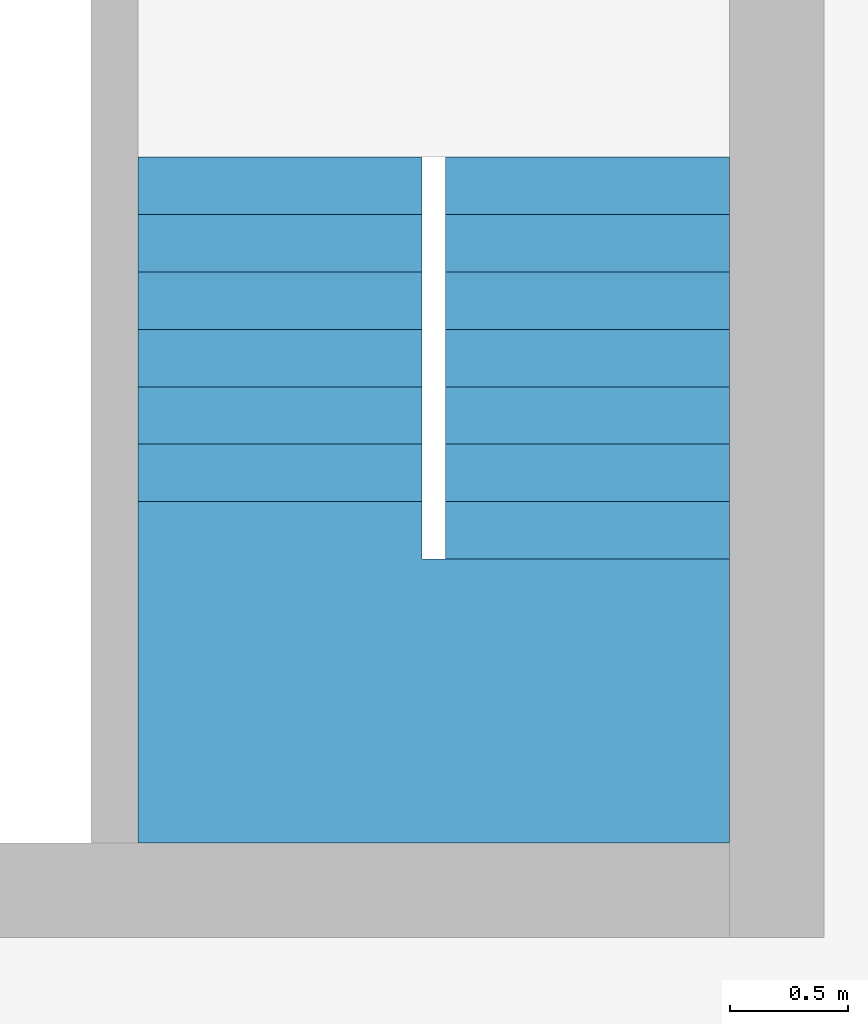
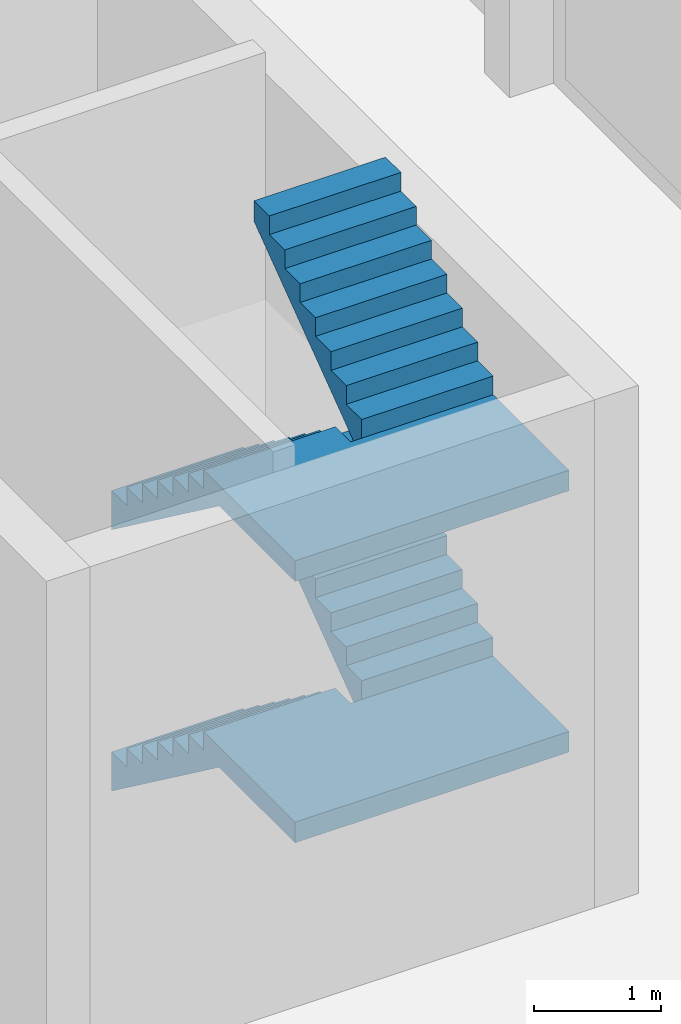
# One storey, part 2 of 5: 2 stairs.
"""IFC2X3 building model written with IfcOpenShell, lengths in metres."""

import ifcopenshell
import ifcopenshell.guid

model = None  # the IFC model being written
_history = None  # IfcOwnerHistory: only IFC2X3 demands one
_inside = {}  # id of a spatial element -> (the spatial element, [elements in it])
_under = {}  # id of a project, library or spatial element -> (it, [spatial elements below it])
_declared = {}  # id of a project -> (the project, [libraries it declares])
_typed = {}  # id of a type object -> (the type object, [elements of that type])
_made_of = {}  # id of a material, layer set ... -> (it, [elements and type objects made of it])


def new_model(schema):
    """Start an empty IFC model of exactly this schema.

    Asked for "IFC4X3", IfcOpenShell would pick the latest addendum, in which some entities
    have other attributes; the version numbers below select the first issue.
    IFC2X3 requires an IfcOwnerHistory on every rooted entity: one is made here for all.
    """
    global model, _history
    if schema == "IFC4X3":
        model = ifcopenshell.file(schema_version=(4, 3, 0, 0))
    else:
        model = ifcopenshell.file(schema=schema)
    _inside.clear()
    _under.clear()
    _declared.clear()
    _typed.clear()
    _made_of.clear()
    _history = None
    if model.schema == "IFC2X3":
        org = make("IfcOrganization", Name="unknown")
        user = make(
            "IfcPersonAndOrganization",
            ThePerson=make("IfcPerson", FamilyName="unknown"),
            TheOrganization=org,
        )
        app = make(
            "IfcApplication",
            ApplicationDeveloper=org,
            Version="unknown",
            ApplicationFullName="unknown",
            ApplicationIdentifier="unknown",
        )
        _history = make(
            "IfcOwnerHistory",
            OwningUser=user,
            OwningApplication=app,
            ChangeAction="ADDED",
            CreationDate=0,
        )
    return model


def make(cls, **values):
    """One entity of the class cls with the attributes given. An attribute that is None is left unset."""
    return model.create_entity(
        cls, **{name: value for name, value in values.items() if value is not None}
    )


def entity(cls, *values):
    """Any entity or typed value of the class cls, its attributes in the order of the schema. None: left unset."""
    e = model.create_entity(cls)
    for i, value in enumerate(values):
        if value is not None:
            e[i] = value
    return e


def rooted(cls, **values):
    """An entity with a GlobalId (a new one), such as an element, a storey or a relation."""
    return make(cls, GlobalId=ifcopenshell.guid.new(), OwnerHistory=_history, **values)


def si_unit(unit_type, name, prefix=None):
    """IfcSIUnit, for example si_unit("LENGTHUNIT", "METRE", prefix="MILLI")."""
    return make("IfcSIUnit", UnitType=unit_type, Prefix=prefix, Name=name)


def converted_unit(unit_type, name, factor, base, dimensions=None, offset=None):
    """IfcConversionBasedUnit, such as the inch: factor (a typed value) times the base unit."""
    return make(
        "IfcConversionBasedUnit"
        if offset is None
        else "IfcConversionBasedUnitWithOffset",
        ConversionOffset=offset,
        Dimensions=None
        if dimensions is None
        else entity("IfcDimensionalExponents", *dimensions),
        UnitType=unit_type,
        Name=name,
        ConversionFactor=make(
            "IfcMeasureWithUnit", ValueComponent=factor, UnitComponent=base
        ),
    )


def assignment(units):
    """IfcUnitAssignment: the units of a project."""
    return None if units is None else make("IfcUnitAssignment", Units=units)


def point(xyz):
    """IfcCartesianPoint."""
    return None if xyz is None else make("IfcCartesianPoint", Coordinates=xyz)


def direction(xyz):
    """IfcDirection."""
    return None if xyz is None else make("IfcDirection", DirectionRatios=xyz)


def frame(location, z_axis=None, x_axis=None):
    """IfcAxis2Placement3D, a coordinate frame: its origin and axes. An axis left out is left unset."""
    return make(
        "IfcAxis2Placement3D",
        Location=point(location),
        Axis=direction(z_axis),
        RefDirection=direction(x_axis),
    )


def origin():
    """The frame at (0, 0, 0) with its axes left unset."""
    return frame((0.0, 0.0, 0.0))


def place(relative_to, where):
    """IfcLocalPlacement: puts the frame where relative to a parent placement (None: the world)."""
    return make(
        "IfcLocalPlacement", PlacementRelTo=relative_to, RelativePlacement=where
    )


def context(
    kind, dimensions, precision=None, world=None, true_north=None, identifier=None
):
    """IfcGeometricRepresentationContext, for example the 3D "Model" context."""
    return make(
        "IfcGeometricRepresentationContext",
        ContextIdentifier=identifier,
        ContextType=kind,
        CoordinateSpaceDimension=dimensions,
        Precision=precision,
        WorldCoordinateSystem=world,
        TrueNorth=true_north,
    )


def subcontext(parent, identifier, kind, view, scale=None):
    """IfcGeometricRepresentationSubContext, for example "Body" below "Model"."""
    return make(
        "IfcGeometricRepresentationSubContext",
        ContextIdentifier=identifier,
        ContextType=kind,
        ParentContext=parent,
        TargetScale=scale,
        TargetView=view,
    )


def project(units=None, contexts=None):
    """IfcProject with its units and contexts."""
    return rooted(
        "IfcProject",
        Name="project",
        RepresentationContexts=contexts,
        UnitsInContext=assignment(units),
    )


def spatial(cls, under=None, at=None, **own):
    """A site, building, storey or space (cls), placed at a placement, below another one or the project."""
    s = rooted(cls, ObjectPlacement=at, **own)
    if under is not None:
        _under.setdefault(under.id(), (under, []))[1].append(s)
    return s


def faces_of(points, faces, orient=None, outer=None):
    """IfcFace entities. A face is a list of loops; a loop is a list of indices into points, from 0.

    orient and outer hold one flag for each loop. By default every Orientation is true, the
    first loop of a face is its IfcFaceOuterBound and the others are IfcFaceBound.
    """
    made = []
    for i, loops in enumerate(faces):
        bounds = []
        for j, loop in enumerate(loops):
            is_outer = j == 0 if outer is None else outer[i][j]
            bounds.append(
                make(
                    "IfcFaceOuterBound" if is_outer else "IfcFaceBound",
                    Bound=make("IfcPolyLoop", Polygon=[points[k] for k in loop]),
                    Orientation=True if orient is None else orient[i][j],
                )
            )
        made.append(make("IfcFace", Bounds=bounds))
    return made


def faceted_brep(points, faces, orient=None, outer=None, voids=None):
    """IfcFacetedBrep: a solid bounded by flat faces; with voids (closed shells), ...WithVoids."""
    shared = [point(p) for p in points]
    hull = make("IfcClosedShell", CfsFaces=faces_of(shared, faces, orient, outer))
    if voids is None:
        return make("IfcFacetedBrep", Outer=hull)
    return make(
        "IfcFacetedBrepWithVoids",
        Outer=hull,
        Voids=[
            make(cls, CfsFaces=faces_of(shared, fs, o, b)) for cls, fs, o, b in voids
        ],
    )


def shape(context_of_items, identifier, shape_type, items):
    """IfcShapeRepresentation: the items that make up one representation, for example the "Body"."""
    return make(
        "IfcShapeRepresentation",
        ContextOfItems=context_of_items,
        RepresentationIdentifier=identifier,
        RepresentationType=shape_type,
        Items=items,
    )


def material(Name=None, Category=None):
    """IfcMaterial."""
    return make("IfcMaterial", Name=Name, Category=Category)


def made_of(thing, what):
    """Note that an element or type object is made of a material, layer set ...; save() writes the relation."""
    if what is not None:
        _made_of.setdefault(what.id(), (what, []))[1].append(thing)
    return thing


def element(
    cls,
    number,
    at=None,
    inside=None,
    cuts=None,
    type_object=None,
    material=None,
    context=None,
    identifier="Body",
    shape_type=None,
    held_by="IfcProductDefinitionShape",
    body=None,
    shapes=None,
    **own,
):
    """One element of the class cls, such as IfcWall. Its Tag is "e" and its number.

    at: its placement. inside: the storey or other place that contains it. cuts: it is an
    opening in that element (IfcRelVoidsElement). A single representation is given by context,
    identifier, shape_type and body (its items); several are given by shapes. held_by: the class
    of the entity that holds the representations. save() writes the other relations.
    """
    e = rooted(cls, Tag="e%d" % number, ObjectPlacement=at, **own)
    if body is not None:
        shapes = [shape(context, identifier, shape_type, body)]
    if shapes is not None:
        e.Representation = make(held_by, Representations=shapes)
    if inside is not None:
        _inside.setdefault(inside.id(), (inside, []))[1].append(e)
    if cuts is not None:
        rooted(
            "IfcRelVoidsElement", RelatingBuildingElement=cuts, RelatedOpeningElement=e
        )
    if type_object is not None:
        _typed.setdefault(type_object.id(), (type_object, []))[1].append(e)
    return made_of(e, material)


def aggregate(whole, parts):
    """IfcRelAggregates: a whole, such as a stair, and the parts it consists of."""
    return rooted("IfcRelAggregates", RelatingObject=whole, RelatedObjects=parts)


def save(model, path):
    """Write the relations noted so far, then the file.

    IfcRelAggregates (storeys below a building ...), IfcRelContainedInSpatialStructure (elements
    in a storey), IfcRelDefinesByType, IfcRelAssociatesMaterial and IfcRelDeclares: one each for
    every whole, place, type object, material and project.
    """
    for whole, parts in _under.values():
        aggregate(whole, parts)
    for where, things in _inside.values():
        rooted(
            "IfcRelContainedInSpatialStructure",
            RelatedElements=things,
            RelatingStructure=where,
        )
    for kind, things in _typed.values():
        rooted("IfcRelDefinesByType", RelatedObjects=things, RelatingType=kind)
    for what, things in _made_of.values():
        rooted("IfcRelAssociatesMaterial", RelatedObjects=things, RelatingMaterial=what)
    for by, libraries in _declared.values():
        rooted("IfcRelDeclares", RelatingContext=by, RelatedDefinitions=libraries)
    model.write(path)


model = new_model("IFC2X3")

# Units and contexts
model_context = context("Model", 3, precision=1e-05, world=origin())
body_context = subcontext(model_context, "Body", "Model", "MODEL_VIEW")
ifc_project = project(units=[si_unit("LENGTHUNIT", "METRE"), si_unit("AREAUNIT", "SQUARE_METRE"), si_unit("VOLUMEUNIT", "CUBIC_METRE"), si_unit("MASSUNIT", "GRAM", prefix="KILO"), converted_unit("PLANEANGLEUNIT", "DEGREE", entity("IfcPlaneAngleMeasure", 0.0174532925199433), si_unit("PLANEANGLEUNIT", "RADIAN"), dimensions=[0, 0, 0, 0, 0, 0, 0])], contexts=[model_context])

# Site, building, storey
site_placement = place(None, origin())
site = spatial("IfcSite", under=ifc_project, at=site_placement, CompositionType="ELEMENT")
building_placement = place(site_placement, origin())
building = spatial("IfcBuilding", under=site, at=building_placement, CompositionType="ELEMENT")
storey_placement = place(building_placement, frame((0.0, 0.0, -0.2)))
storey = spatial("IfcBuildingStorey", under=building, at=storey_placement, Name="Erdgeschoss", CompositionType="ELEMENT", Elevation=-0.2)

# Stairs
ifc_material_1 = material(Name="FT_STB C45")
stair_1_placement = place(storey_placement, frame((22.5, 5.4, 2.52084385635845)))
element("IfcStair", 1, at=stair_1_placement, inside=storey, material=ifc_material_1, Name="I", ShapeType="NOTDEFINED", context=body_context, shape_type="Brep", body=[
    faceted_brep([(2.5, 2.65715714285716, 2.34), (2.5, 2.90000000000001, 2.52), (1.3, 2.90000000000001, 2.52), (1.3, 2.65715714285716, 2.34), (1.3, 2.65715714285716, 2.71915614364155), (1.3, 2.90000000000001, 2.71915614364155), (2.5, 2.90000000000001, 2.71915614364155), (2.5, 2.65715714285716, 2.71915614364155)], [[[0, 1, 2, 3]], [[4, 5, 6, 7]], [[3, 4, 7, 0]], [[0, 7, 6, 1]], [[1, 6, 5, 2]], [[2, 5, 4, 3]]], orient=[[False], [False], [False], [False], [False], [False]]),
    faceted_brep([(2.5, 2.4143142857143, 2.16), (2.5, 2.65715714285716, 2.34), (1.3, 2.65715714285716, 2.34), (1.3, 2.4143142857143, 2.16), (1.3, 2.4143142857143, 2.53915614364155), (1.3, 2.65715714285716, 2.53915614364155), (2.5, 2.65715714285716, 2.53915614364155), (2.5, 2.4143142857143, 2.53915614364155)], [[[0, 1, 2, 3]], [[4, 5, 6, 7]], [[3, 4, 7, 0]], [[0, 7, 6, 1]], [[1, 6, 5, 2]], [[2, 5, 4, 3]]], orient=[[False], [False], [False], [False], [False], [False]]),
    faceted_brep([(2.5, 2.17147142857144, 1.98), (2.5, 2.4143142857143, 2.16), (1.3, 2.4143142857143, 2.16), (1.3, 2.17147142857144, 1.98), (1.3, 2.17147142857144, 2.35915614364155), (1.3, 2.4143142857143, 2.35915614364155), (2.5, 2.4143142857143, 2.35915614364155), (2.5, 2.17147142857144, 2.35915614364155)], [[[0, 1, 2, 3]], [[4, 5, 6, 7]], [[3, 4, 7, 0]], [[0, 7, 6, 1]], [[1, 6, 5, 2]], [[2, 5, 4, 3]]], orient=[[False], [False], [False], [False], [False], [False]]),
    faceted_brep([(2.5, 1.92862857142858, 1.8), (2.5, 2.17147142857144, 1.98), (1.3, 2.17147142857144, 1.98), (1.3, 1.92862857142858, 1.8), (1.3, 1.92862857142858, 2.17915614364155), (1.3, 2.17147142857144, 2.17915614364155), (2.5, 2.17147142857144, 2.17915614364155), (2.5, 1.92862857142858, 2.17915614364155)], [[[0, 1, 2, 3]], [[4, 5, 6, 7]], [[3, 4, 7, 0]], [[0, 7, 6, 1]], [[1, 6, 5, 2]], [[2, 5, 4, 3]]], orient=[[False], [False], [False], [False], [False], [False]]),
    faceted_brep([(2.5, 1.68578571428573, 1.62), (2.5, 1.92862857142858, 1.8), (1.3, 1.92862857142858, 1.8), (1.3, 1.68578571428573, 1.62), (1.3, 1.68578571428573, 1.99915614364155), (1.3, 1.92862857142858, 1.99915614364155), (2.5, 1.92862857142858, 1.99915614364155), (2.5, 1.68578571428573, 1.99915614364155)], [[[0, 1, 2, 3]], [[4, 5, 6, 7]], [[3, 4, 7, 0]], [[0, 7, 6, 1]], [[1, 6, 5, 2]], [[2, 5, 4, 3]]], orient=[[False], [False], [False], [False], [False], [False]]),
    faceted_brep([(2.5, 1.44294285714287, 1.44), (2.5, 1.68578571428573, 1.62), (1.3, 1.68578571428573, 1.62), (1.3, 1.44294285714287, 1.44), (1.3, 1.44294285714287, 1.81915614364155), (1.3, 1.68578571428573, 1.81915614364155), (2.5, 1.68578571428573, 1.81915614364155), (2.5, 1.44294285714287, 1.81915614364155)], [[[0, 1, 2, 3]], [[4, 5, 6, 7]], [[3, 4, 7, 0]], [[0, 7, 6, 1]], [[1, 6, 5, 2]], [[2, 5, 4, 3]]], orient=[[False], [False], [False], [False], [False], [False]]),
    faceted_brep([(2.5, 1.20010000000001, 1.26), (2.5, 1.44294285714287, 1.44), (1.3, 1.44294285714287, 1.44), (1.3, 1.20010000000001, 1.26), (1.3, 1.20010000000001, 1.63915614364155), (1.3, 1.44294285714287, 1.63915614364155), (2.5, 1.44294285714287, 1.63915614364155), (2.5, 1.20010000000001, 1.63915614364155)], [[[0, 1, 2, 3]], [[4, 5, 6, 7]], [[3, 4, 7, 0]], [[0, 7, 6, 1]], [[1, 6, 5, 2]], [[2, 5, 4, 3]]], orient=[[False], [False], [False], [False], [False], [False]]),
    faceted_brep([(1.2, 1.2001, 1.26), (0.0, 1.2001, 1.26), (0.0, 5.45696821063757e-15, 1.26), (1.201, 1.81898940354586e-15, 1.26), (1.201, 1.2, 1.26), (1.2, 1.2, 1.26), (0.0, 1.2001, 1.45915614364155), (1.2, 1.2001, 1.45915614364155), (1.2, 1.2, 1.45915614364155), (1.201, 1.2, 1.45915614364155), (1.201, 1.81898940354586e-15, 1.45915614364155), (0.0, 5.45696821063757e-15, 1.45915614364155)], [[[0, 1, 2, 3, 4, 5]], [[6, 7, 8, 9, 10, 11]], [[1, 0, 7, 6]], [[2, 1, 6, 11]], [[3, 2, 11, 10]], [[4, 3, 10, 9]], [[5, 4, 9, 8]], [[0, 5, 8, 7]]], orient=[[False], [False], [False], [False], [False], [False], [False], [False]]),
    faceted_brep([(0.0, 1.44294285714286, 1.08), (0.0, 1.2001, 1.26), (1.2, 1.2001, 1.26), (1.2, 1.44294285714286, 1.08), (1.2, 1.44294285714286, 1.45915614364155), (1.2, 1.2001, 1.45915614364155), (0.0, 1.2001, 1.45915614364155), (0.0, 1.44294285714286, 1.45915614364155)], [[[0, 1, 2, 3]], [[4, 5, 6, 7]], [[3, 4, 7, 0]], [[0, 7, 6, 1]], [[1, 6, 5, 2]], [[2, 5, 4, 3]]], orient=[[False], [False], [False], [False], [False], [False]]),
    faceted_brep([(0.0, 1.68578571428572, 0.9), (0.0, 1.44294285714286, 1.08), (1.2, 1.44294285714286, 1.08), (1.2, 1.68578571428572, 0.9), (1.2, 1.68578571428572, 1.27915614364155), (1.2, 1.44294285714286, 1.27915614364155), (0.0, 1.44294285714286, 1.27915614364155), (0.0, 1.68578571428572, 1.27915614364155)], [[[0, 1, 2, 3]], [[4, 5, 6, 7]], [[3, 4, 7, 0]], [[0, 7, 6, 1]], [[1, 6, 5, 2]], [[2, 5, 4, 3]]], orient=[[False], [False], [False], [False], [False], [False]]),
    faceted_brep([(0.0, 1.92862857142858, 0.72), (0.0, 1.68578571428572, 0.9), (1.2, 1.68578571428572, 0.9), (1.2, 1.92862857142858, 0.72), (1.2, 1.92862857142858, 1.09915614364155), (1.2, 1.68578571428572, 1.09915614364155), (0.0, 1.68578571428572, 1.09915614364155), (0.0, 1.92862857142858, 1.09915614364155)], [[[0, 1, 2, 3]], [[4, 5, 6, 7]], [[3, 4, 7, 0]], [[0, 7, 6, 1]], [[1, 6, 5, 2]], [[2, 5, 4, 3]]], orient=[[False], [False], [False], [False], [False], [False]]),
    faceted_brep([(0.0, 2.17147142857143, 0.54), (0.0, 1.92862857142858, 0.72), (1.2, 1.92862857142858, 0.72), (1.2, 2.17147142857143, 0.54), (1.2, 2.17147142857143, 0.919156143641549), (1.2, 1.92862857142858, 0.919156143641549), (0.0, 1.92862857142858, 0.919156143641549), (0.0, 2.17147142857143, 0.919156143641549)], [[[0, 1, 2, 3]], [[4, 5, 6, 7]], [[3, 4, 7, 0]], [[0, 7, 6, 1]], [[1, 6, 5, 2]], [[2, 5, 4, 3]]], orient=[[False], [False], [False], [False], [False], [False]]),
    faceted_brep([(0.0, 2.41431428571429, 0.36), (0.0, 2.17147142857143, 0.54), (1.2, 2.17147142857143, 0.54), (1.2, 2.41431428571429, 0.36), (1.2, 2.41431428571429, 0.739156143641549), (1.2, 2.17147142857143, 0.739156143641549), (0.0, 2.17147142857143, 0.739156143641549), (0.0, 2.41431428571429, 0.739156143641549)], [[[0, 1, 2, 3]], [[4, 5, 6, 7]], [[3, 4, 7, 0]], [[0, 7, 6, 1]], [[1, 6, 5, 2]], [[2, 5, 4, 3]]], orient=[[False], [False], [False], [False], [False], [False]]),
    faceted_brep([(0.0, 2.65715714285715, 0.18), (0.0, 2.41431428571429, 0.36), (1.2, 2.41431428571429, 0.36), (1.2, 2.65715714285715, 0.18), (1.2, 2.65715714285715, 0.559156143641549), (1.2, 2.41431428571429, 0.559156143641549), (0.0, 2.41431428571429, 0.559156143641549), (0.0, 2.65715714285715, 0.559156143641549)], [[[0, 1, 2, 3]], [[4, 5, 6, 7]], [[3, 4, 7, 0]], [[0, 7, 6, 1]], [[1, 6, 5, 2]], [[2, 5, 4, 3]]], orient=[[False], [False], [False], [False], [False], [False]]),
    faceted_brep([(0.0, 2.90000000000001, 4.54747350886464e-16), (0.0, 2.65715714285715, 0.18), (1.2, 2.65715714285715, 0.18), (1.2, 2.90000000000001, 4.54747350886464e-16), (1.2, 2.90000000000001, 0.379156143641549), (1.2, 2.65715714285715, 0.379156143641549), (0.0, 2.65715714285715, 0.379156143641549), (0.0, 2.90000000000001, 0.379156143641549)], [[[0, 1, 2, 3]], [[4, 5, 6, 7]], [[3, 4, 7, 0]], [[0, 7, 6, 1]], [[1, 6, 5, 2]], [[2, 5, 4, 3]]], orient=[[False], [False], [False], [False], [False], [False]]),
    faceted_brep([(1.201, 1.2, 1.26), (1.201, 1.81898940354586e-15, 1.26), (2.5, 0.0, 1.26), (2.5, 1.20010000000001, 1.26), (1.3, 1.20010000000001, 1.26), (1.3, 1.20000000000001, 1.26), (1.201, 1.81898940354586e-15, 1.45915614364155), (1.201, 1.2, 1.45915614364155), (1.3, 1.20000000000001, 1.45915614364155), (1.3, 1.20010000000001, 1.45915614364155), (2.5, 1.20010000000001, 1.45915614364155), (2.5, 0.0, 1.45915614364155)], [[[0, 1, 2, 3, 4, 5]], [[6, 7, 8, 9, 10, 11]], [[1, 0, 7, 6]], [[2, 1, 6, 11]], [[3, 2, 11, 10]], [[4, 3, 10, 9]], [[5, 4, 9, 8]], [[0, 5, 8, 7]]], orient=[[False], [False], [False], [False], [False], [False], [False], [False]]),
])
ifc_material_2 = material(Name="FT_STB C45")
stair_2_placement = place(storey_placement, frame((22.5, 5.4, 0.000843856358451717)))
element("IfcStair", 2, at=stair_2_placement, inside=storey, material=ifc_material_2, Name="I", ShapeType="NOTDEFINED", context=body_context, shape_type="Brep", body=[
    faceted_brep([(1.2, 1.2001, 1.26), (0.0, 1.2001, 1.26), (0.0, 5.45696821063757e-15, 1.26), (1.201, 1.81898940354586e-15, 1.26), (1.201, 1.2, 1.26), (1.2, 1.2, 1.26), (0.0, 1.2001, 1.45915614364155), (1.2, 1.2001, 1.45915614364155), (1.2, 1.2, 1.45915614364155), (1.201, 1.2, 1.45915614364155), (1.201, 1.81898940354586e-15, 1.45915614364155), (0.0, 5.45696821063757e-15, 1.45915614364155)], [[[0, 1, 2, 3, 4, 5]], [[6, 7, 8, 9, 10, 11]], [[1, 0, 7, 6]], [[2, 1, 6, 11]], [[3, 2, 11, 10]], [[4, 3, 10, 9]], [[5, 4, 9, 8]], [[0, 5, 8, 7]]], orient=[[False], [False], [False], [False], [False], [False], [False], [False]]),
    faceted_brep([(0.0, 1.44294285714286, 1.08), (0.0, 1.2001, 1.26), (1.2, 1.2001, 1.26), (1.2, 1.44294285714286, 1.08), (1.2, 1.44294285714286, 1.45915614364155), (1.2, 1.2001, 1.45915614364155), (0.0, 1.2001, 1.45915614364155), (0.0, 1.44294285714286, 1.45915614364155)], [[[0, 1, 2, 3]], [[4, 5, 6, 7]], [[3, 4, 7, 0]], [[0, 7, 6, 1]], [[1, 6, 5, 2]], [[2, 5, 4, 3]]], orient=[[False], [False], [False], [False], [False], [False]]),
    faceted_brep([(0.0, 1.68578571428572, 0.9), (0.0, 1.44294285714286, 1.08), (1.2, 1.44294285714286, 1.08), (1.2, 1.68578571428572, 0.9), (1.2, 1.68578571428572, 1.27915614364155), (1.2, 1.44294285714286, 1.27915614364155), (0.0, 1.44294285714286, 1.27915614364155), (0.0, 1.68578571428572, 1.27915614364155)], [[[0, 1, 2, 3]], [[4, 5, 6, 7]], [[3, 4, 7, 0]], [[0, 7, 6, 1]], [[1, 6, 5, 2]], [[2, 5, 4, 3]]], orient=[[False], [False], [False], [False], [False], [False]]),
    faceted_brep([(0.0, 1.92862857142858, 0.72), (0.0, 1.68578571428572, 0.9), (1.2, 1.68578571428572, 0.9), (1.2, 1.92862857142858, 0.72), (1.2, 1.92862857142858, 1.09915614364155), (1.2, 1.68578571428572, 1.09915614364155), (0.0, 1.68578571428572, 1.09915614364155), (0.0, 1.92862857142858, 1.09915614364155)], [[[0, 1, 2, 3]], [[4, 5, 6, 7]], [[3, 4, 7, 0]], [[0, 7, 6, 1]], [[1, 6, 5, 2]], [[2, 5, 4, 3]]], orient=[[False], [False], [False], [False], [False], [False]]),
    faceted_brep([(0.0, 2.17147142857143, 0.54), (0.0, 1.92862857142858, 0.72), (1.2, 1.92862857142858, 0.72), (1.2, 2.17147142857143, 0.54), (1.2, 2.17147142857143, 0.919156143641548), (1.2, 1.92862857142858, 0.919156143641548), (0.0, 1.92862857142858, 0.919156143641548), (0.0, 2.17147142857143, 0.919156143641548)], [[[0, 1, 2, 3]], [[4, 5, 6, 7]], [[3, 4, 7, 0]], [[0, 7, 6, 1]], [[1, 6, 5, 2]], [[2, 5, 4, 3]]], orient=[[False], [False], [False], [False], [False], [False]]),
    faceted_brep([(0.0, 2.41431428571429, 0.36), (0.0, 2.17147142857143, 0.54), (1.2, 2.17147142857143, 0.54), (1.2, 2.41431428571429, 0.36), (1.2, 2.41431428571429, 0.739156143641548), (1.2, 2.17147142857143, 0.739156143641548), (0.0, 2.17147142857143, 0.739156143641548), (0.0, 2.41431428571429, 0.739156143641548)], [[[0, 1, 2, 3]], [[4, 5, 6, 7]], [[3, 4, 7, 0]], [[0, 7, 6, 1]], [[1, 6, 5, 2]], [[2, 5, 4, 3]]], orient=[[False], [False], [False], [False], [False], [False]]),
    faceted_brep([(0.0, 2.65715714285715, 0.18), (0.0, 2.41431428571429, 0.36), (1.2, 2.41431428571429, 0.36), (1.2, 2.65715714285715, 0.18), (1.2, 2.65715714285715, 0.559156143641548), (1.2, 2.41431428571429, 0.559156143641548), (0.0, 2.41431428571429, 0.559156143641548), (0.0, 2.65715714285715, 0.559156143641548)], [[[0, 1, 2, 3]], [[4, 5, 6, 7]], [[3, 4, 7, 0]], [[0, 7, 6, 1]], [[1, 6, 5, 2]], [[2, 5, 4, 3]]], orient=[[False], [False], [False], [False], [False], [False]]),
    faceted_brep([(0.0, 2.90000000000001, 0.0), (0.0, 2.65715714285715, 0.18), (1.2, 2.65715714285715, 0.18), (1.2, 2.90000000000001, 0.0), (1.2, 2.90000000000001, 0.379156143641548), (1.2, 2.65715714285715, 0.379156143641548), (0.0, 2.65715714285715, 0.379156143641548), (0.0, 2.90000000000001, 0.379156143641548)], [[[0, 1, 2, 3]], [[4, 5, 6, 7]], [[3, 4, 7, 0]], [[0, 7, 6, 1]], [[1, 6, 5, 2]], [[2, 5, 4, 3]]], orient=[[False], [False], [False], [False], [False], [False]]),
    faceted_brep([(2.5, 2.65715714285715, 2.34), (2.5, 2.90000000000001, 2.52), (1.3, 2.90000000000001, 2.52), (1.3, 2.65715714285715, 2.34), (1.3, 2.65715714285715, 2.71915614364155), (1.3, 2.90000000000001, 2.71915614364155), (2.5, 2.90000000000001, 2.71915614364155), (2.5, 2.65715714285715, 2.71915614364155)], [[[0, 1, 2, 3]], [[4, 5, 6, 7]], [[3, 4, 7, 0]], [[0, 7, 6, 1]], [[1, 6, 5, 2]], [[2, 5, 4, 3]]], orient=[[False], [False], [False], [False], [False], [False]]),
    faceted_brep([(2.5, 2.41431428571429, 2.16), (2.5, 2.65715714285715, 2.34), (1.3, 2.65715714285715, 2.34), (1.3, 2.41431428571429, 2.16), (1.3, 2.41431428571429, 2.53915614364155), (1.3, 2.65715714285715, 2.53915614364155), (2.5, 2.65715714285715, 2.53915614364155), (2.5, 2.41431428571429, 2.53915614364155)], [[[0, 1, 2, 3]], [[4, 5, 6, 7]], [[3, 4, 7, 0]], [[0, 7, 6, 1]], [[1, 6, 5, 2]], [[2, 5, 4, 3]]], orient=[[False], [False], [False], [False], [False], [False]]),
    faceted_brep([(2.5, 2.17147142857143, 1.98), (2.5, 2.41431428571429, 2.16), (1.3, 2.41431428571429, 2.16), (1.3, 2.17147142857143, 1.98), (1.3, 2.17147142857143, 2.35915614364155), (1.3, 2.41431428571429, 2.35915614364155), (2.5, 2.41431428571429, 2.35915614364155), (2.5, 2.17147142857143, 2.35915614364155)], [[[0, 1, 2, 3]], [[4, 5, 6, 7]], [[3, 4, 7, 0]], [[0, 7, 6, 1]], [[1, 6, 5, 2]], [[2, 5, 4, 3]]], orient=[[False], [False], [False], [False], [False], [False]]),
    faceted_brep([(2.5, 1.92862857142858, 1.8), (2.5, 2.17147142857143, 1.98), (1.3, 2.17147142857143, 1.98), (1.3, 1.92862857142858, 1.8), (1.3, 1.92862857142858, 2.17915614364155), (1.3, 2.17147142857143, 2.17915614364155), (2.5, 2.17147142857143, 2.17915614364155), (2.5, 1.92862857142858, 2.17915614364155)], [[[0, 1, 2, 3]], [[4, 5, 6, 7]], [[3, 4, 7, 0]], [[0, 7, 6, 1]], [[1, 6, 5, 2]], [[2, 5, 4, 3]]], orient=[[False], [False], [False], [False], [False], [False]]),
    faceted_brep([(2.5, 1.68578571428572, 1.62), (2.5, 1.92862857142858, 1.8), (1.3, 1.92862857142858, 1.8), (1.3, 1.68578571428572, 1.62), (1.3, 1.68578571428572, 1.99915614364155), (1.3, 1.92862857142858, 1.99915614364155), (2.5, 1.92862857142858, 1.99915614364155), (2.5, 1.68578571428572, 1.99915614364155)], [[[0, 1, 2, 3]], [[4, 5, 6, 7]], [[3, 4, 7, 0]], [[0, 7, 6, 1]], [[1, 6, 5, 2]], [[2, 5, 4, 3]]], orient=[[False], [False], [False], [False], [False], [False]]),
    faceted_brep([(2.5, 1.44294285714286, 1.44), (2.5, 1.68578571428572, 1.62), (1.3, 1.68578571428572, 1.62), (1.3, 1.44294285714286, 1.44), (1.3, 1.44294285714286, 1.81915614364155), (1.3, 1.68578571428572, 1.81915614364155), (2.5, 1.68578571428572, 1.81915614364155), (2.5, 1.44294285714286, 1.81915614364155)], [[[0, 1, 2, 3]], [[4, 5, 6, 7]], [[3, 4, 7, 0]], [[0, 7, 6, 1]], [[1, 6, 5, 2]], [[2, 5, 4, 3]]], orient=[[False], [False], [False], [False], [False], [False]]),
    faceted_brep([(1.201, 1.2, 1.26), (1.201, 1.81898940354586e-15, 1.26), (2.5, 0.0, 1.26), (2.5, 1.20010000000001, 1.26), (1.3, 1.20010000000001, 1.26), (1.3, 1.20000000000001, 1.26), (1.201, 1.81898940354586e-15, 1.45915614364155), (1.201, 1.2, 1.45915614364155), (1.3, 1.20000000000001, 1.45915614364155), (1.3, 1.20010000000001, 1.45915614364155), (2.5, 1.20010000000001, 1.45915614364155), (2.5, 0.0, 1.45915614364155)], [[[0, 1, 2, 3, 4, 5]], [[6, 7, 8, 9, 10, 11]], [[1, 0, 7, 6]], [[2, 1, 6, 11]], [[3, 2, 11, 10]], [[4, 3, 10, 9]], [[5, 4, 9, 8]], [[0, 5, 8, 7]]], orient=[[False], [False], [False], [False], [False], [False], [False], [False]]),
    faceted_brep([(2.5, 1.20010000000001, 1.26), (2.5, 1.44294285714286, 1.44), (1.3, 1.44294285714286, 1.44), (1.3, 1.20010000000001, 1.26), (1.3, 1.20010000000001, 1.63915614364155), (1.3, 1.44294285714286, 1.63915614364155), (2.5, 1.44294285714286, 1.63915614364155), (2.5, 1.20010000000001, 1.63915614364155)], [[[0, 1, 2, 3]], [[4, 5, 6, 7]], [[3, 4, 7, 0]], [[0, 7, 6, 1]], [[1, 6, 5, 2]], [[2, 5, 4, 3]]], orient=[[False], [False], [False], [False], [False], [False]]),
])

save(model, "model.ifc")
